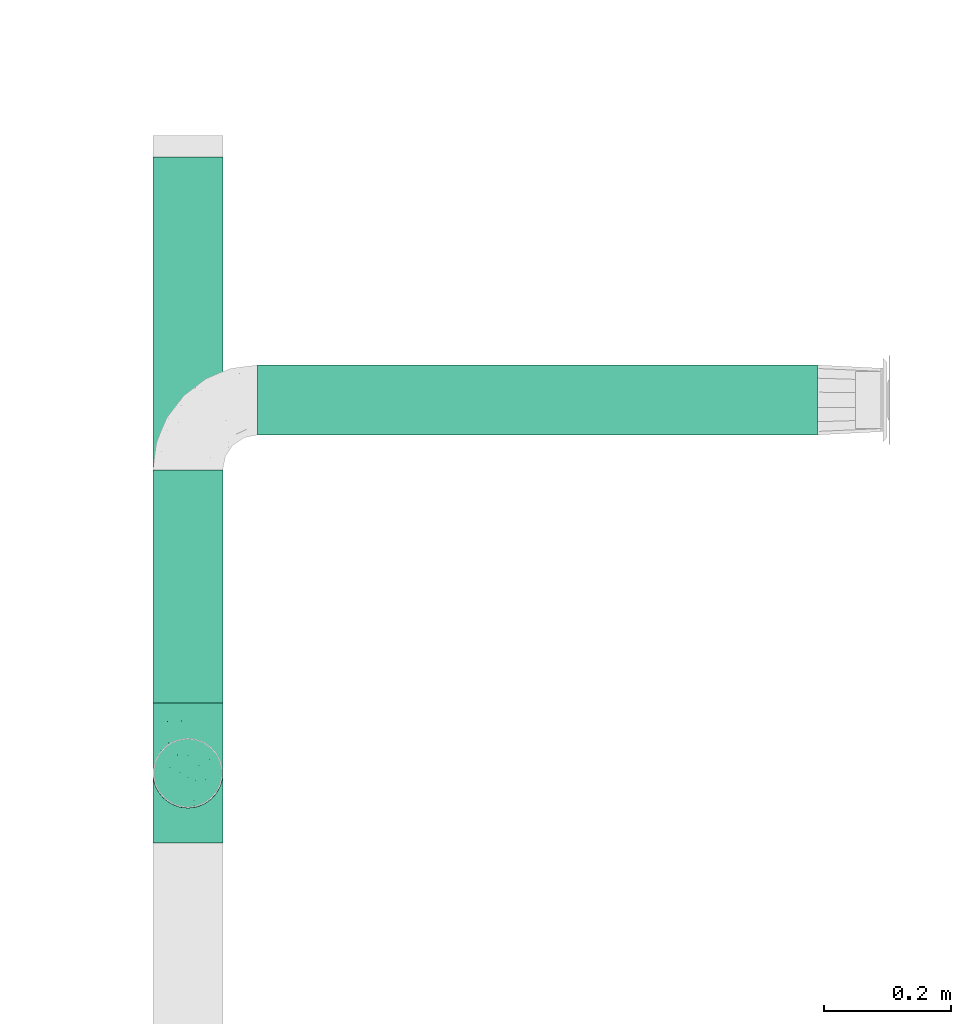
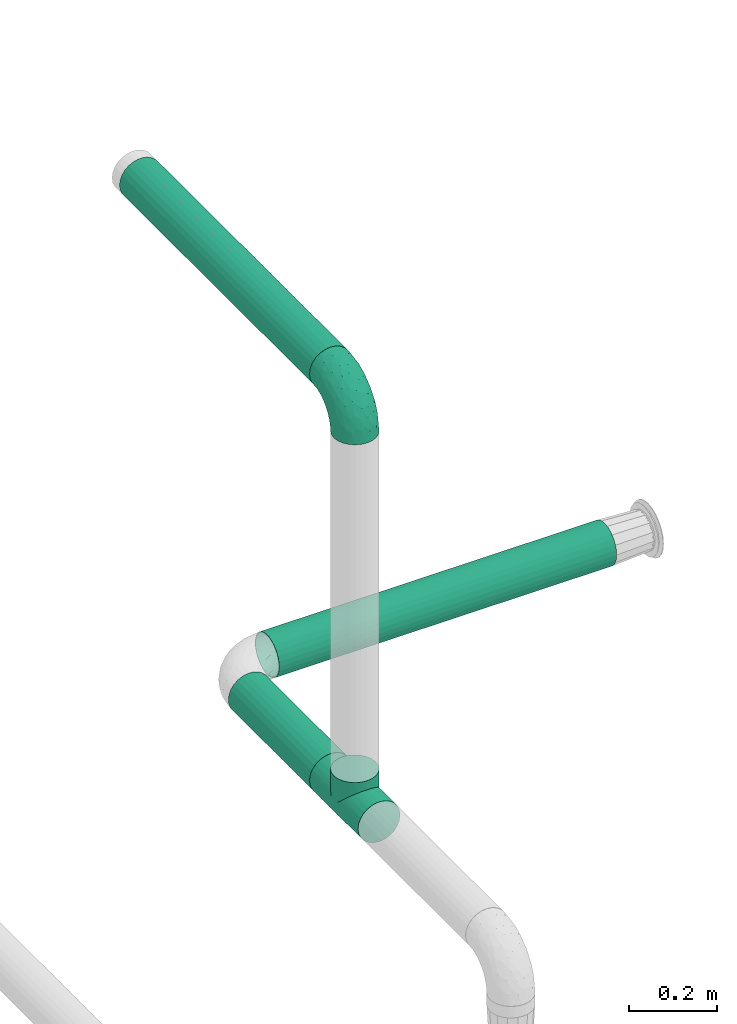
# One storey, part 98 of 103: 3 flow segments, 2 flow fittings.
"""IFC2X3 building model written with IfcOpenShell, lengths in millimetres."""

from ifc_helpers import new_model, entity, si_unit, converted_unit, derived_unit, direction, frame, origin_with_axes, origin_2d_with_axis, place, context, subcontext, project, spatial, hollow_circle, extrude, open_shell, surface_model, source, transform, mapped, material, layer, layer_set, layer_usage, type_object, element, save


model = new_model("IFC2X3")

# Units and contexts
model_context = context("Model", 3, precision=1e-05, world=origin_with_axes(), true_north=direction((0.0, 1.0)))
body_context = subcontext(model_context, "Body", "Model", "MODEL_VIEW")
ifc_project = project(units=[si_unit("AREAUNIT", "SQUARE_METRE"), si_unit("VOLUMEUNIT", "CUBIC_METRE", prefix="DECI"), si_unit("TIMEUNIT", "SECOND"), si_unit("THERMODYNAMICTEMPERATUREUNIT", "DEGREE_CELSIUS"), si_unit("PRESSUREUNIT", "PASCAL"), si_unit("MASSUNIT", "GRAM", prefix="KILO"), si_unit("LENGTHUNIT", "METRE", prefix="MILLI"), si_unit("POWERUNIT", "WATT"), si_unit("ELECTRICCURRENTUNIT", "AMPERE"), si_unit("ELECTRICVOLTAGEUNIT", "VOLT"), derived_unit("VOLUMETRICFLOWRATEUNIT", [(si_unit("VOLUMEUNIT", "CUBIC_METRE", prefix="DECI"), 1), (si_unit("TIMEUNIT", "SECOND"), -1)]), derived_unit("LINEARVELOCITYUNIT", [(si_unit("LENGTHUNIT", "METRE"), 1), (si_unit("TIMEUNIT", "SECOND"), -1)]), derived_unit("MASSDENSITYUNIT", [(si_unit("MASSUNIT", "GRAM", prefix="KILO"), 1), (si_unit("VOLUMEUNIT", "CUBIC_METRE"), -1)]), converted_unit("PLANEANGLEUNIT", "DEGREE", entity("IfcRatioMeasure", 0.01745), si_unit("PLANEANGLEUNIT", "RADIAN"), dimensions=[0, 0, 0, 0, 0, 0, 0])], contexts=[model_context])

# Site, building, storey
site_placement = place(None, origin_with_axes())
site = spatial("IfcSite", under=ifc_project, at=site_placement, CompositionType="ELEMENT")
building_placement = place(site_placement, origin_with_axes())
building = spatial("IfcBuilding", under=site, at=building_placement, Name="mc-building", CompositionType="ELEMENT")
storey_placement = place(building_placement, frame((0.0, 0.0, 5900.0), z_axis=(0.0, 0.0, 1.0), x_axis=(1.0, 0.0, 0.0)))
storey = spatial("IfcBuildingStorey", under=building, at=storey_placement, Name="3. Korrus", CompositionType="ELEMENT", Elevation=5900.0)

# Flow fitting
duct_fitting_type_1 = type_object("IfcDuctFittingType", PredefinedType="JUNCTION")
shared_shape_1 = source(origin_with_axes(), body_context, "Body", "SurfaceModel", [
    surface_model("IfcShellBasedSurfaceModel", [(0.0, -80.0, -55.0), (14.23505, -80.0, -53.12592), (-14.23505, -80.0, -53.12592), (-53.12592, -80.0, 14.23505), (-27.5, -80.0, -47.63139), (-47.63139, -80.0, -27.5), (-38.89087, -80.0, -38.89087), (55.0, -80.0, 0.0), (53.12592, -80.0, 14.23505), (38.89087, -80.0, -38.89087), (27.5, -80.0, -47.63139), (53.12592, -80.0, -14.23505), (47.63139, -80.0, -27.5), (-53.12592, -80.0, -14.23505), (-47.63139, -80.0, 27.5), (-38.89087, -80.0, 38.89087), (14.23505, -80.0, 53.12592), (-27.5, -80.0, 47.63139), (-14.23505, -80.0, 53.12592), (47.63139, -80.0, 27.5), (38.89087, -80.0, 38.89087), (27.5, -80.0, 47.63139), (0.0, -80.0, 55.0), (-55.0, -80.0, 0.0), (0.0, 0.0, 55.0), (-7.4066, -7.4066, 54.49901), (-14.74521, -14.74521, 52.98659), (-21.93978, -21.93978, 50.43457), (-28.89905, -28.89905, 46.79578), (-35.50357, -35.50357, 42.00591), (-41.58668, -41.58668, 35.99373), (-46.92319, -46.92319, 28.69171), (-51.19777, -51.19777, 20.0945), (-50.37866, -80.0, 20.86752), (-54.01174, -54.01174, 10.37938), (-55.0, -55.0, 0.0), (-54.06296, -80.0, 7.11752), (-54.01174, -54.01174, -10.37938), (-51.19777, -51.19777, -20.0945), (-54.06296, -80.0, -7.11752), (-46.92319, -46.92319, -28.69171), (-41.58668, -41.58668, -35.99373), (-50.37866, -80.0, -20.86752), (-35.50357, -35.50357, -42.00591), (-21.93978, -21.93978, -50.43457), (-14.74521, -14.74521, -52.98659), (-7.4066, -7.4066, -54.49901), (0.0, 0.0, -55.0), (-28.89905, -28.89905, -46.79578), (7.4066, -7.4066, -54.49901), (14.74521, -14.74521, -52.98659), (21.93978, -21.93978, -50.43457), (28.89905, -28.89905, -46.79578), (35.50357, -35.50357, -42.00591), (41.58668, -41.58668, -35.99373), (46.92319, -46.92319, -28.69171), (51.19777, -51.19777, -20.0945), (50.37866, -80.0, -20.86752), (54.01174, -54.01174, -10.37938), (55.0, -55.0, 0.0), (54.06296, -80.0, -7.11752), (54.01174, -54.01174, 10.37938), (51.19777, -51.19777, 20.0945), (54.06296, -80.0, 7.11752), (46.92319, -46.92319, 28.69171), (41.58668, -41.58668, 35.99373), (50.37866, -80.0, 20.86752), (35.50357, -35.50357, 42.00591), (21.93978, -21.93978, 50.43457), (14.74521, -14.74521, 52.98659), (7.4066, -7.4066, 54.49901), (28.89905, -28.89905, 46.79578), (-110.0, 0.0, -55.0), (-110.0, -14.23505, -53.12592), (-110.0, 14.23505, -53.12592), (-110.0, 53.12592, 14.23505), (-110.0, 27.5, -47.63139), (-110.0, 47.63139, -27.5), (-110.0, 38.89087, -38.89087), (-110.0, -55.0, 0.0), (-110.0, -53.12592, 14.23505), (-110.0, -38.89087, -38.89087), (-110.0, -27.5, -47.63139), (-110.0, -53.12592, -14.23505), (-110.0, -47.63139, -27.5), (-110.0, 53.12592, -14.23505), (-110.0, 47.63139, 27.5), (-110.0, 38.89087, 38.89087), (-110.0, -14.23505, 53.12592), (-110.0, 27.5, 47.63139), (-110.0, 14.23505, 53.12592), (-110.0, -47.63139, 27.5), (-110.0, -38.89087, 38.89087), (-110.0, -27.5, 47.63139), (-110.0, 0.0, 55.0), (-110.0, 55.0, 0.0), (110.0, 55.0, 0.0), (110.0, 0.0, -55.0), (110.0, 14.23505, -53.12592), (110.0, 27.5, -47.63139), (110.0, 38.89087, -38.89087), (110.0, 47.63139, -27.5), (110.0, -38.89087, -38.89087), (110.0, -53.12592, 14.23505), (110.0, -27.5, -47.63139), (110.0, -14.23505, -53.12592), (110.0, -47.63139, -27.5), (110.0, -53.12592, -14.23505), (110.0, -55.0, 0.0), (110.0, 53.12592, -14.23505), (110.0, 53.12592, 14.23505), (110.0, 47.63139, 27.5), (110.0, 38.89087, 38.89087), (110.0, 0.0, 55.0), (110.0, 27.5, 47.63139), (110.0, 14.23505, 53.12592), (110.0, -47.63139, 27.5), (110.0, -38.89087, 38.89087), (110.0, -27.5, 47.63139), (110.0, -14.23505, 53.12592)], [open_shell([[[0, 1, 2]], [[2, 3, 4]], [[5, 6, 3]], [[6, 4, 3]], [[2, 7, 8]], [[9, 7, 10]], [[1, 10, 7]], [[11, 7, 12]], [[9, 12, 7]], [[7, 2, 1]], [[5, 3, 13]], [[2, 14, 3]], [[2, 15, 14]], [[2, 16, 17]], [[17, 15, 2]], [[16, 18, 17]], [[2, 8, 19]], [[2, 19, 20]], [[2, 20, 21]], [[16, 2, 21]], [[16, 22, 18]], [[23, 13, 3]], [[24, 25, 22]], [[26, 27, 18]], [[25, 26, 18]], [[22, 25, 18]], [[17, 28, 29]], [[17, 18, 27]], [[17, 29, 15]], [[28, 17, 27]], [[30, 31, 14]], [[32, 3, 33]], [[32, 34, 3]], [[35, 36, 34]], [[31, 32, 14]], [[15, 30, 14]], [[34, 36, 3]], [[33, 14, 32]], [[36, 35, 23]], [[30, 15, 29]], [[37, 38, 13]], [[37, 13, 39]], [[40, 41, 5]], [[38, 5, 42]], [[38, 40, 5]], [[37, 39, 35]], [[35, 39, 23]], [[13, 38, 42]], [[41, 6, 5]], [[41, 43, 6]], [[44, 45, 2]], [[46, 47, 0]], [[45, 46, 2]], [[43, 48, 4]], [[44, 4, 48]], [[44, 2, 4]], [[46, 0, 2]], [[43, 4, 6]], [[47, 49, 0]], [[50, 51, 1]], [[49, 50, 1]], [[0, 49, 1]], [[10, 52, 53]], [[10, 1, 51]], [[10, 53, 9]], [[52, 10, 51]], [[54, 55, 12]], [[56, 11, 57]], [[56, 58, 11]], [[59, 60, 58]], [[55, 56, 12]], [[9, 54, 12]], [[58, 60, 11]], [[57, 12, 56]], [[60, 59, 7]], [[54, 9, 53]], [[61, 62, 8]], [[61, 8, 63]], [[64, 65, 19]], [[62, 19, 66]], [[62, 64, 19]], [[61, 63, 59]], [[7, 59, 63]], [[62, 66, 8]], [[65, 20, 19]], [[65, 67, 20]], [[68, 69, 16]], [[70, 24, 22]], [[69, 70, 16]], [[67, 71, 21]], [[68, 21, 71]], [[68, 16, 21]], [[70, 22, 16]], [[67, 21, 20]], [[72, 73, 74]], [[74, 75, 76]], [[77, 78, 75]], [[76, 75, 78]], [[74, 79, 80]], [[81, 79, 82]], [[73, 82, 79]], [[83, 79, 84]], [[81, 84, 79]], [[79, 74, 73]], [[77, 75, 85]], [[74, 86, 75]], [[74, 87, 86]], [[74, 88, 89]], [[89, 87, 74]], [[88, 90, 89]], [[74, 91, 92]], [[91, 74, 80]], [[92, 93, 74]], [[74, 93, 88]], [[88, 94, 90]], [[95, 85, 75]], [[96, 97, 98]], [[99, 96, 98]], [[96, 100, 101]], [[100, 96, 99]], [[102, 97, 103]], [[97, 102, 104]], [[104, 105, 97]], [[102, 103, 106]], [[106, 103, 107]], [[108, 107, 103]], [[109, 96, 101]], [[110, 111, 97]], [[97, 111, 112]], [[113, 97, 114]], [[97, 112, 114]], [[113, 114, 115]], [[116, 103, 97]], [[117, 116, 97]], [[118, 117, 97]], [[119, 118, 97]], [[119, 97, 113]], [[96, 110, 97]], [[24, 113, 115]], [[89, 115, 114]], [[94, 24, 90]], [[90, 24, 115]], [[115, 89, 90]], [[114, 87, 89]], [[86, 112, 111]], [[75, 111, 110]], [[95, 110, 96]], [[87, 112, 86]], [[86, 111, 75]], [[110, 95, 75]], [[112, 87, 114]], [[85, 96, 109]], [[77, 109, 101]], [[95, 96, 85]], [[85, 109, 77]], [[101, 78, 77]], [[101, 100, 78]], [[76, 100, 99]], [[74, 99, 98]], [[47, 98, 97]], [[76, 99, 74]], [[47, 72, 74]], [[98, 47, 74]], [[100, 76, 78]], [[47, 46, 72]], [[45, 44, 73]], [[46, 45, 73]], [[72, 46, 73]], [[82, 48, 43]], [[82, 73, 44]], [[82, 43, 81]], [[48, 82, 44]], [[41, 40, 84]], [[38, 37, 83]], [[40, 38, 84]], [[81, 41, 84]], [[37, 79, 83]], [[83, 84, 38]], [[79, 37, 35]], [[41, 81, 43]], [[49, 97, 105]], [[105, 104, 51]], [[53, 104, 102]], [[53, 52, 104]], [[49, 47, 97]], [[51, 50, 105]], [[52, 51, 104]], [[49, 105, 50]], [[54, 102, 106]], [[56, 106, 107]], [[58, 107, 108]], [[55, 54, 106]], [[58, 56, 107]], [[59, 58, 108]], [[55, 106, 56]], [[102, 54, 53]], [[34, 32, 80]], [[31, 30, 91]], [[32, 31, 91]], [[35, 34, 79]], [[80, 79, 34]], [[32, 91, 80]], [[30, 92, 91]], [[30, 29, 92]], [[27, 26, 88]], [[25, 24, 94]], [[26, 25, 88]], [[29, 28, 93]], [[27, 93, 28]], [[27, 88, 93]], [[25, 94, 88]], [[29, 93, 92]], [[61, 108, 103]], [[62, 103, 116]], [[65, 116, 117]], [[61, 59, 108]], [[64, 62, 116]], [[65, 64, 116]], [[61, 103, 62]], [[117, 67, 65]], [[71, 67, 118]], [[118, 67, 117]], [[68, 118, 119]], [[70, 119, 113]], [[68, 71, 118]], [[70, 69, 119]], [[24, 70, 113]], [[68, 119, 69]]])]),
])
flow_fitting_1_placement = place(storey_placement, frame((34114.97365, 8890.09332, 2345.0), z_axis=(1.0, 0.0, 0.0), x_axis=(0.0, -1.0, 0.0)))
element("IfcFlowFitting", 1, at=flow_fitting_1_placement, inside=storey, type_object=duct_fitting_type_1, context=body_context, shape_type="MappedRepresentation", body=[
    mapped(shared_shape_1, transform((0.0, 0.0, 0.0), scale=1.0)),
])

# Flow segments
ifc_material = material(Name="FZ1")
ifc_layer = layer(ifc_material, 0.0)
ifc_layer_set = layer_set([ifc_layer], Name="FZ1")
ifc_layer_usage = layer_usage(ifc_layer_set, "AXIS1", "POSITIVE", 0.0)
duct_segment_type = type_object("IfcDuctSegmentType", PredefinedType="RIGIDSEGMENT")
shared_shape_2 = source(origin_with_axes(), body_context, "Body", "SweptSolid", [
    extrude(hollow_circle(Radius=55.0, WallThickness=2.0, at=origin_2d_with_axis()), frame((0.0, 0.0, 0.0), z_axis=(1.0, 0.0, 0.0), x_axis=(0.0, 1.0, 0.0)), (0.0, 0.0, 1.0), 881.8),
])
flow_segment_1_placement = place(storey_placement, frame((35106.81103, 9477.62755, 2345.0), z_axis=(0.0, 0.0, 1.0), x_axis=(-1.0, 0.0, 0.0)))
element("IfcFlowSegment", 2, at=flow_segment_1_placement, inside=storey, type_object=duct_segment_type, material=ifc_layer_usage, context=body_context, shape_type="MappedRepresentation", body=[
    mapped(shared_shape_2, transform((0.0, 0.0, 0.0), scale=1.0)),
])
shared_shape_3 = source(origin_with_axes(), body_context, "Body", "SweptSolid", [
    extrude(hollow_circle(Radius=55.0, WallThickness=2.0, at=origin_2d_with_axis()), frame((0.0, 0.0, 0.0), z_axis=(1.0, 0.0, 0.0), x_axis=(0.0, 1.0, 0.0)), (0.0, 0.0, 1.0), 367.5),
])
flow_segment_2_placement = place(storey_placement, frame((34114.97365, 9367.62755, 2345.0), z_axis=(0.0, 0.0, 1.0), x_axis=(0.0, -1.0, 0.0)))
element("IfcFlowSegment", 3, at=flow_segment_2_placement, inside=storey, type_object=duct_segment_type, material=ifc_layer_usage, context=body_context, shape_type="MappedRepresentation", body=[
    mapped(shared_shape_3, transform((0.0, 0.0, 0.0), scale=1.0)),
])
shared_shape_4 = source(origin_with_axes(), body_context, "Body", "SweptSolid", [
    extrude(hollow_circle(Radius=55.0, WallThickness=2.0, at=origin_2d_with_axis()), frame((0.0, 0.0, 0.0), z_axis=(1.0, 0.0, 0.0), x_axis=(0.0, 1.0, 0.0)), (0.0, 0.0, 1.0), 860.0),
])
flow_segment_3_placement = place(storey_placement, frame((34114.97365, 9860.05037, 3468.0), z_axis=(0.0, 0.0, 1.0), x_axis=(0.0, -1.0, 0.0)))
element("IfcFlowSegment", 4, at=flow_segment_3_placement, inside=storey, type_object=duct_segment_type, material=ifc_layer_usage, context=body_context, shape_type="MappedRepresentation", body=[
    mapped(shared_shape_4, transform((0.0, 0.0, 0.0), scale=1.0)),
])

# Flow fitting
duct_fitting_type_2 = type_object("IfcDuctFittingType", Name="BU", PredefinedType="BEND")
shared_shape_5 = source(origin_with_axes(), body_context, "Body", "SurfaceModel", [
    surface_model("IfcShellBasedSurfaceModel", [(-110.0, 0.0, -55.0), (-110.0, -14.23505, -53.12592), (-110.0, 14.23505, -53.12592), (-110.0, 53.12592, 14.23505), (-110.0, 27.5, -47.63139), (-110.0, 38.89087, -38.89087), (-110.0, -55.0, 0.0), (-110.0, -53.12592, 14.23505), (-110.0, -38.89087, -38.89087), (-110.0, -27.5, -47.63139), (-110.0, -53.12592, -14.23505), (-110.0, -47.63139, -27.5), (-110.0, -14.23505, 53.12592), (-110.0, 14.23505, 53.12592), (-110.0, 27.5, 47.63139), (-110.0, -47.63139, 27.5), (-110.0, -38.89087, 38.89087), (-110.0, -27.5, 47.63139), (-110.0, 0.0, 55.0), (-110.0, 55.0, 0.0), (-110.0, 53.12592, -14.23505), (-110.0, 47.63139, -27.5), (-110.0, 47.63139, 27.5), (-110.0, 38.89087, 38.89087), (-14.23505, 110.0, -53.12592), (-55.0, 110.0, 0.0), (0.0, 110.0, -55.0), (-27.5, 110.0, -47.63139), (-38.89087, 110.0, -38.89087), (-47.63139, 110.0, -27.5), (38.89087, 110.0, -38.89087), (53.12592, 110.0, 14.23505), (27.5, 110.0, -47.63139), (14.23505, 110.0, -53.12592), (47.63139, 110.0, -27.5), (53.12592, 110.0, -14.23505), (55.0, 110.0, 0.0), (-53.12592, 110.0, -14.23505), (-53.12592, 110.0, 14.23505), (-47.63139, 110.0, 27.5), (-38.89087, 110.0, 38.89087), (-27.5, 110.0, 47.63139), (0.0, 110.0, 55.0), (-14.23505, 110.0, 53.12592), (38.89087, 110.0, 38.89087), (47.63139, 110.0, 27.5), (27.5, 110.0, 47.63139), (14.23505, 110.0, 53.12592), (-64.21732, 48.68956, 43.63444), (-76.6405, 38.18013, 45.55988), (-60.44912, 32.56953, 51.94617), (-76.00813, 5.38378, 55.0), (-90.15553, 11.94394, 54.09138), (-78.5998, 26.77405, 50.81338), (-70.18771, 18.55163, 54.03432), (-75.55424, 54.2118, 32.41257), (-93.27622, 45.77614, 33.48188), (-96.12334, 22.13664, 50.81337), (-21.00813, 45.34362, 55.0), (-18.36258, 70.48427, 54.04484), (-32.04182, 59.64019, 52.24446), (-63.88653, 74.77858, 17.99134), (-74.66383, 63.08407, 19.92123), (-63.60674, 66.07878, 29.97482), (-99.597, 52.72185, 18.52927), (-93.11138, 56.59448, 10.50359), (-98.21577, 57.34403, 0.0), (-53.42855, 92.60092, 21.04759), (-88.54852, 54.8376, 21.04759), (-11.86161, 90.23965, 54.10313), (-5.38378, 76.00813, 55.0), (-57.34403, 98.21577, 0.0), (-56.64619, 93.12774, 10.22088), (-45.34362, 21.00813, 55.0), (-44.60838, 44.60838, 52.13415), (-92.68484, 35.46673, 43.63443), (-22.25266, 95.40765, 50.81337), (-35.97783, 90.61597, 43.63443), (-43.70931, 69.58671, 44.47149), (-27.23711, 77.39884, 50.81337), (-57.2828, 79.3123, 24.9774), (-58.67786, 84.31125, 16.04456), (-82.93277, 60.36161, 12.91784), (-49.88337, 54.51816, 47.224), (-74.57753, 66.83759, 9.55742), (-45.35812, 94.97281, 33.48188), (-59.18663, 88.95241, 0.0), (-51.517, 78.6292, 33.48188), (-65.14788, 80.03077, 0.0), (-56.45322, 62.06476, 39.63545), (-88.95241, 59.18663, 0.0), (-71.10913, 71.10913, 0.0), (-80.03077, 65.14788, 0.0), (-94.9309, 45.36788, -33.48188), (-93.11358, 56.60141, -10.46614), (-99.64997, 52.79499, -18.30015), (-90.20425, 36.08686, -43.63443), (-79.99933, 46.56772, -37.92748), (-76.00813, 5.38378, -55.0), (-72.75364, 19.68651, -53.60527), (-45.34362, 21.00813, -55.0), (-21.91957, 65.12078, -53.85897), (-5.38378, 76.00813, -55.0), (-21.00813, 45.34362, -55.0), (-35.41876, 92.89265, -43.63443), (-91.10309, 11.02766, -54.21832), (-45.77614, 93.27622, -33.48188), (-90.50474, 23.21022, -50.81337), (-70.92854, 33.31794, -49.51754), (-78.52933, 63.35627, -11.73997), (-24.91508, 84.05606, -50.81337), (-88.78941, 54.74452, -21.04759), (-69.59921, 57.34866, -33.48187), (-73.36422, 62.46673, -22.94182), (-63.49062, 67.59111, -28.46929), (-56.59448, 93.11138, -10.50359), (-54.8376, 88.54852, -21.04759), (-54.10679, 75.85581, -32.31867), (-57.75956, 31.09612, -52.80882), (-52.72185, 99.597, -18.52927), (-12.62913, 89.46304, -53.99097), (-34.46825, 66.46123, -50.04329), (-43.9837, 43.9837, -52.42279), (-65.78527, 72.58348, -17.68796), (-70.34468, 43.65295, -44.21951), (-57.47001, 51.99467, -44.91465), (-60.72547, 82.29174, -12.88567), (-42.34915, 74.24548, -43.63444), (-57.25194, 63.5016, -38.08211), (-80.95344, 53.56991, -29.32027), (-52.32891, 4.55257, -54.0482), (32.52942, 47.13398, -30.48571), (14.88266, 20.92917, -33.7947), (14.95561, 36.05775, -42.26543), (30.24048, 70.09027, -41.7461), (19.3559, 65.35825, -48.00507), (-70.35075, -46.44478, -19.5952), (-47.13398, -32.52942, -30.48571), (-28.49299, -30.5778, -16.4009), (-4.55257, 52.32891, -54.0482), (-22.4954, 22.4954, -53.25347), (-75.47368, -11.22546, -52.60718), (-81.32209, -51.5606, -9.98467), (-80.81763, -41.84862, -32.14655), (-70.09027, -30.24048, -41.7461), (-36.05774, -14.95561, -42.26543), (-9.15831, -10.852, -27.8997), (-65.35825, -19.3559, -48.00507), (11.22546, 75.47368, -52.60718), (3.94376, 43.9333, -50.53315), (-13.39742, 13.39743, -48.13058), (-43.9333, -3.94376, -50.53315), (49.37776, 67.29486, 0.0), (41.8609, 47.82256, -9.92641), (50.20582, 74.51695, -9.9731), (18.93131, 11.7156, -17.56239), (-27.5, -32.89419, 0.0), (-1.23348, -12.25375, -12.18106), (41.84862, 80.81763, -32.14655), (35.70604, 41.31408, -20.38235), (46.44478, 70.35075, -19.5952), (32.89419, 27.5, 0.0), (6.67262, -6.67262, 0.0), (-67.29486, -49.37776, 0.0), (-50.36265, -42.95545, -9.51562), (-5.47251, 5.47251, -39.92906), (-70.35075, -46.44478, 19.5952), (-74.51695, -50.20582, 9.9731), (-41.31407, -35.70604, 20.38235), (-47.13398, -32.52942, 30.48571), (-80.81763, -41.84862, 32.14655), (-4.55257, 52.32891, 54.0482), (11.22546, 75.47368, 52.60718), (-43.9333, -3.94376, 50.53315), (-65.35825, -19.3559, 48.00507), (-36.05774, -14.95561, 42.26543), (-70.09027, -30.24048, 41.7461), (-11.7156, -18.93131, 17.56239), (30.5778, 28.49299, 16.4009), (12.25375, 1.23348, 12.18106), (51.5606, 81.32209, 9.98467), (42.95545, 50.36265, 9.51562), (-75.47368, -11.22546, 52.60718), (-52.32891, 4.55257, 54.0482), (3.94376, 43.9333, 50.53315), (-22.4954, 22.4954, 53.25347), (-13.39742, 13.39743, 48.13058), (10.852, 9.15831, 27.8997), (-20.92916, -14.88266, 33.79469), (-47.82256, -41.8609, 9.92641), (32.52942, 47.13398, 30.48571), (46.44478, 70.35075, 19.5952), (41.84862, 80.81763, 32.14655), (30.24048, 70.09027, 41.7461), (19.3559, 65.35825, 48.00507), (14.95561, 36.05775, 42.26543), (-5.47251, 5.47251, 39.92906)], [open_shell([[[0, 1, 2]], [[2, 3, 4]], [[4, 3, 5]], [[2, 6, 7]], [[8, 6, 9]], [[1, 9, 6]], [[10, 6, 11]], [[8, 11, 6]], [[6, 2, 1]], [[12, 13, 14]], [[15, 2, 7]], [[16, 17, 2]], [[2, 17, 12]], [[12, 18, 13]], [[19, 20, 3]], [[5, 3, 21]], [[20, 21, 3]], [[22, 3, 2]], [[23, 22, 2]], [[12, 14, 2]], [[2, 14, 23]], [[15, 16, 2]], [[24, 25, 26]], [[27, 25, 24]], [[25, 28, 29]], [[28, 25, 27]], [[30, 26, 31]], [[26, 30, 32]], [[32, 33, 26]], [[34, 31, 35]], [[31, 34, 30]], [[35, 31, 36]], [[29, 37, 25]], [[38, 39, 26]], [[39, 40, 26]], [[41, 42, 40]], [[42, 26, 40]], [[42, 41, 43]], [[26, 44, 45]], [[31, 26, 45]], [[26, 46, 44]], [[47, 46, 26]], [[42, 47, 26]], [[25, 38, 26]], [[48, 49, 50]], [[18, 51, 52]], [[53, 54, 50]], [[55, 56, 49]], [[56, 22, 23]], [[13, 57, 14]], [[58, 59, 60]], [[61, 62, 63]], [[3, 64, 65]], [[53, 52, 54]], [[3, 65, 66]], [[67, 39, 38]], [[56, 68, 64]], [[65, 64, 68]], [[69, 59, 70]], [[38, 71, 72]], [[73, 58, 74]], [[75, 49, 56]], [[76, 69, 43]], [[53, 57, 52]], [[77, 78, 79]], [[41, 76, 43]], [[43, 69, 42]], [[55, 68, 56]], [[23, 14, 75]], [[76, 77, 79]], [[80, 67, 81]], [[62, 82, 68]], [[60, 78, 83]], [[62, 84, 82]], [[85, 77, 40]], [[81, 67, 72]], [[86, 72, 71]], [[87, 85, 67]], [[61, 81, 88]], [[77, 41, 40]], [[78, 77, 87]], [[23, 75, 56]], [[83, 89, 48]], [[85, 40, 39]], [[62, 68, 55]], [[89, 87, 63]], [[83, 48, 50]], [[57, 75, 14]], [[49, 75, 53]], [[67, 85, 39]], [[87, 77, 85]], [[63, 62, 55]], [[89, 55, 48]], [[80, 63, 87]], [[66, 65, 90]], [[66, 19, 3]], [[84, 91, 92]], [[92, 90, 82]], [[65, 82, 90]], [[61, 84, 62]], [[92, 82, 84]], [[68, 82, 65]], [[3, 22, 64]], [[56, 64, 22]], [[38, 25, 71]], [[81, 72, 86]], [[38, 72, 67]], [[91, 61, 88]], [[80, 81, 61]], [[63, 80, 61]], [[67, 80, 87]], [[77, 76, 41]], [[79, 59, 69]], [[79, 69, 76]], [[42, 69, 70]], [[60, 59, 79]], [[58, 70, 59]], [[78, 60, 79]], [[58, 60, 74]], [[52, 57, 13]], [[75, 57, 53]], [[18, 52, 13]], [[52, 51, 54]], [[51, 73, 54]], [[50, 73, 74]], [[73, 50, 54]], [[50, 74, 83]], [[60, 83, 74]], [[89, 83, 78]], [[87, 89, 78]], [[55, 89, 63]], [[50, 49, 53]], [[55, 49, 48]], [[81, 86, 88]], [[91, 84, 61]], [[5, 21, 93]], [[90, 94, 66]], [[20, 94, 95]], [[96, 93, 97]], [[98, 99, 100]], [[96, 4, 5]], [[101, 102, 103]], [[28, 27, 104]], [[2, 105, 0]], [[104, 106, 28]], [[99, 105, 107]], [[108, 107, 96]], [[90, 109, 94]], [[107, 2, 4]], [[20, 66, 94]], [[27, 24, 110]], [[109, 111, 94]], [[112, 113, 114]], [[37, 115, 71]], [[116, 106, 117]], [[99, 118, 100]], [[116, 115, 119]], [[37, 119, 115]], [[24, 120, 110]], [[121, 110, 101]], [[119, 106, 116]], [[101, 110, 120]], [[122, 103, 100]], [[117, 123, 116]], [[124, 125, 108]], [[115, 116, 126]], [[106, 29, 28]], [[26, 102, 120]], [[127, 104, 110]], [[97, 124, 96]], [[125, 122, 118]], [[128, 127, 125]], [[96, 5, 93]], [[115, 126, 86]], [[117, 106, 127]], [[111, 113, 129]], [[95, 93, 21]], [[97, 129, 112]], [[110, 104, 27]], [[106, 104, 127]], [[96, 107, 4]], [[99, 107, 108]], [[99, 108, 118]], [[105, 99, 98]], [[112, 114, 128]], [[121, 125, 127]], [[20, 19, 66]], [[109, 90, 92]], [[94, 111, 95]], [[91, 123, 109]], [[129, 113, 112]], [[93, 95, 111]], [[21, 20, 95]], [[71, 115, 86]], [[71, 25, 37]], [[123, 91, 88]], [[126, 116, 123]], [[123, 88, 126]], [[86, 126, 88]], [[37, 29, 119]], [[106, 119, 29]], [[129, 93, 111]], [[124, 112, 125]], [[0, 105, 98]], [[107, 105, 2]], [[125, 118, 108]], [[100, 118, 122]], [[93, 129, 97]], [[113, 111, 109]], [[109, 123, 113]], [[114, 123, 117]], [[123, 114, 113]], [[128, 114, 117]], [[127, 128, 117]], [[112, 128, 125]], [[103, 122, 101]], [[110, 121, 127]], [[101, 122, 121]], [[125, 121, 122]], [[26, 120, 24]], [[101, 120, 102]], [[96, 124, 108]], [[92, 91, 109]], [[112, 124, 97]], [[100, 130, 98]], [[131, 132, 133]], [[32, 134, 135]], [[136, 137, 138]], [[139, 140, 103]], [[98, 141, 0]], [[142, 10, 136]], [[143, 144, 137]], [[6, 10, 142]], [[137, 145, 146]], [[144, 147, 145]], [[143, 136, 11]], [[11, 136, 10]], [[8, 143, 11]], [[148, 149, 139]], [[8, 9, 144]], [[9, 1, 147]], [[130, 141, 98]], [[103, 140, 100]], [[148, 135, 149]], [[150, 151, 140]], [[152, 153, 154]], [[130, 140, 151]], [[148, 26, 33]], [[147, 1, 141]], [[155, 146, 132]], [[156, 138, 157]], [[134, 30, 158]], [[150, 140, 149]], [[158, 30, 34]], [[30, 134, 32]], [[153, 159, 160]], [[131, 160, 159]], [[144, 145, 137]], [[36, 152, 154]], [[146, 138, 137]], [[155, 161, 162]], [[158, 160, 131]], [[133, 149, 135]], [[156, 163, 164]], [[163, 142, 164]], [[139, 103, 102]], [[153, 152, 161]], [[34, 35, 160]], [[162, 157, 155]], [[132, 165, 133]], [[157, 146, 155]], [[140, 130, 100]], [[141, 130, 151]], [[141, 151, 147]], [[141, 1, 0]], [[102, 26, 148]], [[140, 139, 149]], [[102, 148, 139]], [[135, 33, 32]], [[151, 150, 145]], [[9, 147, 144]], [[151, 145, 147]], [[145, 165, 146]], [[135, 148, 33]], [[133, 135, 134]], [[131, 133, 134]], [[133, 165, 150]], [[133, 150, 149]], [[145, 150, 165]], [[132, 131, 159]], [[146, 165, 132]], [[160, 158, 34]], [[134, 158, 131]], [[144, 143, 8]], [[136, 143, 137]], [[155, 153, 161]], [[154, 153, 160]], [[153, 155, 159]], [[132, 159, 155]], [[160, 35, 154]], [[36, 154, 35]], [[164, 136, 138]], [[6, 142, 163]], [[136, 164, 142]], [[156, 164, 138]], [[156, 157, 162]], [[146, 157, 138]], [[15, 7, 166]], [[6, 163, 167]], [[168, 169, 166]], [[166, 169, 170]], [[171, 172, 70]], [[173, 174, 175]], [[17, 176, 174]], [[177, 156, 162]], [[176, 16, 170]], [[170, 16, 15]], [[161, 178, 179]], [[152, 180, 181]], [[182, 173, 183]], [[18, 12, 182]], [[184, 185, 186]], [[183, 185, 73]], [[183, 73, 51]], [[177, 187, 188]], [[189, 168, 166]], [[187, 178, 190]], [[16, 176, 17]], [[161, 152, 181]], [[45, 191, 31]], [[45, 44, 192]], [[192, 191, 45]], [[180, 36, 31]], [[193, 194, 195]], [[46, 47, 194]], [[193, 195, 190]], [[193, 44, 46]], [[172, 42, 70]], [[185, 58, 73]], [[189, 163, 156]], [[163, 189, 167]], [[70, 58, 171]], [[184, 171, 185]], [[169, 188, 175]], [[180, 31, 191]], [[192, 193, 190]], [[191, 190, 178]], [[182, 174, 173]], [[194, 47, 172]], [[190, 195, 187]], [[186, 185, 173]], [[162, 179, 177]], [[188, 196, 175]], [[179, 187, 177]], [[185, 171, 58]], [[172, 171, 184]], [[172, 184, 194]], [[172, 47, 42]], [[51, 18, 182]], [[185, 183, 173]], [[51, 182, 183]], [[174, 12, 17]], [[184, 186, 195]], [[46, 194, 193]], [[184, 195, 194]], [[195, 196, 187]], [[174, 182, 12]], [[175, 174, 176]], [[169, 175, 176]], [[175, 196, 186]], [[175, 186, 173]], [[195, 186, 196]], [[188, 169, 168]], [[187, 196, 188]], [[166, 170, 15]], [[176, 170, 169]], [[193, 192, 44]], [[191, 192, 190]], [[177, 189, 156]], [[167, 189, 166]], [[189, 177, 168]], [[188, 168, 177]], [[166, 7, 167]], [[6, 167, 7]], [[181, 191, 178]], [[36, 180, 152]], [[191, 181, 180]], [[161, 181, 178]], [[161, 179, 162]], [[187, 179, 178]]])]),
])
flow_fitting_2_placement = place(storey_placement, frame((34114.97365, 8890.09332, 3468.0), z_axis=(-1.0, 0.0, 0.0), x_axis=(0.0, 0.0, 1.0)))
element("IfcFlowFitting", 5, at=flow_fitting_2_placement, inside=storey, type_object=duct_fitting_type_2, Name="BU", context=body_context, shape_type="MappedRepresentation", body=[
    mapped(shared_shape_5, transform((0.0, 0.0, 0.0), scale=1.0)),
])

save(model, "model.ifc")
